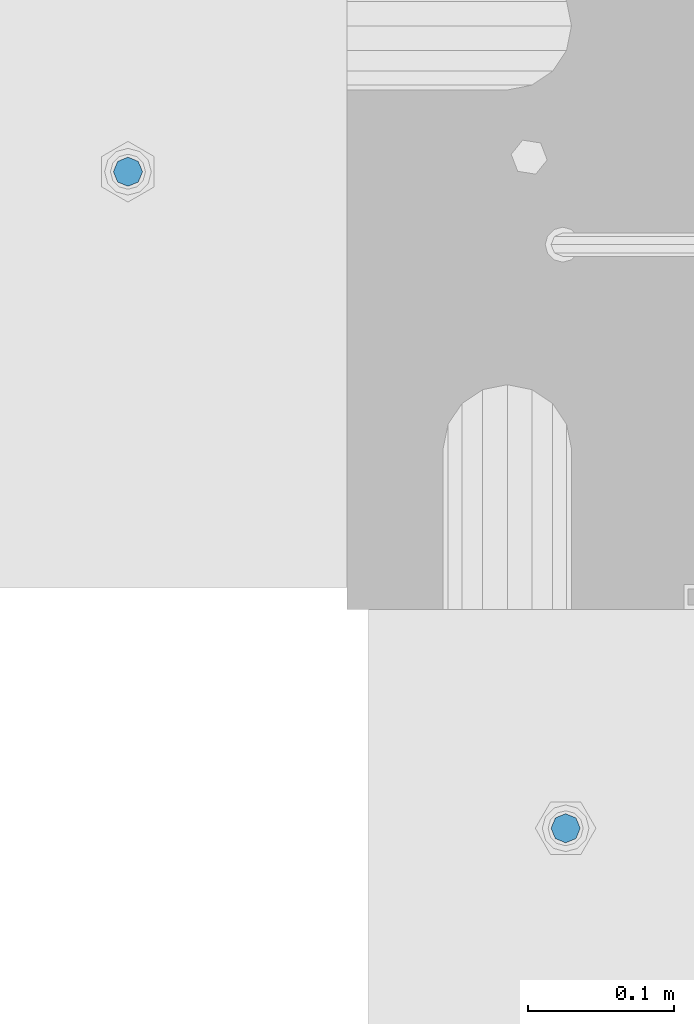
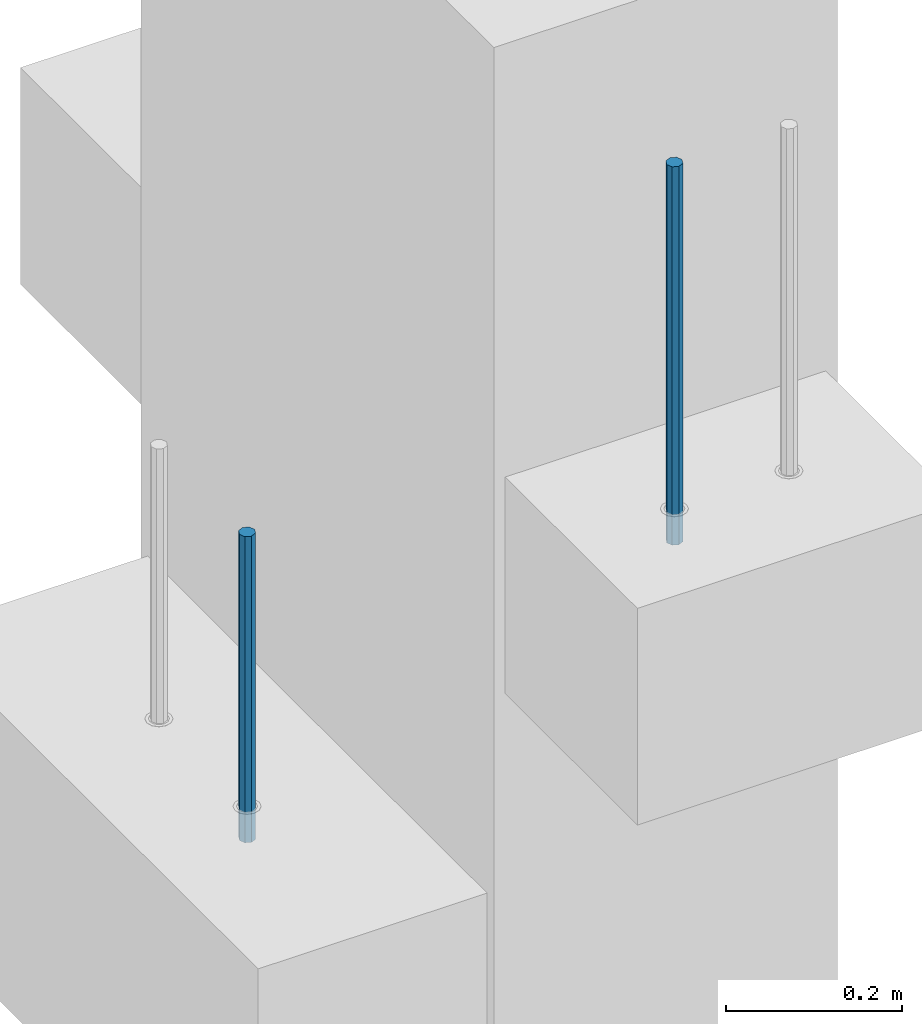
# One storey, part 13 of 41: 2 beams, 1 element without a shape of its own.
"""IFC2X3 building model written with IfcOpenShell, lengths in millimetres."""

from ifc_helpers import new_model, si_unit, frame, origin_with_axes, place, context, subcontext, project, spatial, faceted_brep, material, type_object, element, aggregate, save


model = new_model("IFC2X3")

# Units and contexts
model_context = context("Model", 3, precision=1e-05, world=origin_with_axes())
body_context = subcontext(model_context, "Body", "Model", "MODEL_VIEW")
ifc_project = project(units=[si_unit("LENGTHUNIT", "METRE", prefix="MILLI"), si_unit("AREAUNIT", "SQUARE_METRE"), si_unit("VOLUMEUNIT", "CUBIC_METRE"), si_unit("MASSUNIT", "GRAM", prefix="KILO"), si_unit("TIMEUNIT", "SECOND"), si_unit("PLANEANGLEUNIT", "RADIAN"), si_unit("SOLIDANGLEUNIT", "STERADIAN"), si_unit("THERMODYNAMICTEMPERATUREUNIT", "DEGREE_CELSIUS"), si_unit("LUMINOUSINTENSITYUNIT", "LUMEN")], contexts=[model_context])

# Site, building, storey
site_placement = place(None, frame((-177556.685383467, -198018.589999756, 1290.0), z_axis=(0.0, 0.0, 1.0), x_axis=(0.788225611989142, -0.615386370180835, 0.0)))
site = spatial("IfcSite", under=ifc_project, at=site_placement, CompositionType="ELEMENT")
building_placement = place(site_placement, origin_with_axes())
building = spatial("IfcBuilding", under=site, at=building_placement, Name="Undefined", CompositionType="ELEMENT")
storey_placement = place(building_placement, origin_with_axes())
storey = spatial("IfcBuildingStorey", under=building, at=storey_placement, Name="Undefined", CompositionType="ELEMENT", Elevation=0.0)

# Assembly, beams
assembly_placement = place(storey_placement, origin_with_axes())
assembly = element("IfcElementAssembly", 1, at=assembly_placement, inside=storey, AssemblyPlace="NOTDEFINED", PredefinedType="REINFORCEMENT_UNIT")
ifc_material = material(Name="STEEL/S235JR")
beam_type = type_object("IfcBeamType", PredefinedType="NOTDEFINED")
beam_1_placement = place(assembly_placement, frame((18376.1312535663, 264869.610342897, 17750.0), z_axis=(0.615386370178831, -0.788225611990706, 0.0), x_axis=(0.0, 0.0, -1.0)))
beam_1 = element("IfcBeam", 2, at=beam_1_placement, type_object=beam_type, material=ifc_material, context=body_context, shape_type="Brep", body=[
    faceted_brep([(4.88085788674653e-07, -10.0, -3.86498868465424e-08), (0.0, -7.07106819456385, -7.07106766643119), (524.0, -7.07106759562157, -7.07106811032281), (524.0, -9.99999978375854, -2.98430677503347e-07), (4.97872867461239e-11, -3.88578058618805e-15, -10.0), (524.0, 2.16212356463075e-07, -10.000000298518), (0.0, 7.07106742914766, -7.0710676664894), (524.0, 7.07106802810449, -7.07106811041012), (4.88085788674653e-07, 10.0, -3.86498868465424e-08), (524.0, 10.0000002162415, -2.98547092825174e-07), (0.0, 7.07106742919132, 7.07106795720756), (524.0, 7.0710680281336, 7.07106751331594), (-4.97872867461239e-11, 0.0, 10.0), (524.0, 2.16299667954445e-07, 9.99999970148201), (0.0, -7.07106819453475, 7.07106795729487), (524.0, -7.07106759559247, 7.07106751340325)], [[[0, 1, 2, 3]], [[1, 4, 5, 2]], [[4, 6, 7, 5]], [[6, 8, 9, 7]], [[8, 10, 11, 9]], [[10, 12, 13, 11]], [[12, 14, 15, 13]], [[14, 0, 3, 15]], [[5, 7, 9, 11, 13, 15, 3, 2]], [[14, 12, 10, 8, 6, 4, 1, 0]]]),
])
beam_2_placement = place(assembly_placement, frame((17862.7397033917, 265039.69595724, 17070.0), z_axis=(-0.788225611989142, -0.615386370180835, 0.0), x_axis=(0.0, 0.0, -1.0)))
beam_2 = element("IfcBeam", 3, at=beam_2_placement, type_object=beam_type, material=ifc_material, context=body_context, shape_type="Brep", body=[
    faceted_brep([(4.88085788674653e-07, -10.0, -3.86498868465424e-08), (0.0, -7.07106819456385, -7.07106766643119), (424.0, -7.07106751357787, -7.07106759684393), (424.0, -9.99999970174395, 2.15019099414349e-07), (4.97872867461239e-11, -3.88578058618805e-15, -10.0), (424.0, 2.98285158351064e-07, -9.9999997849518), (0.0, 7.07106742914766, -7.0710676664894), (424.0, 7.07106811014819, -7.07106759675662), (4.88085788674653e-07, 10.0, -3.86498868465424e-08), (424.0, 10.0000002982561, 2.15106410905719e-07), (0.0, 7.07106742919132, 7.07106795720756), (424.0, 7.07106811011909, 7.07106802696944), (-4.97872867461239e-11, 0.0, 10.0), (424.0, 2.98256054520607e-07, 10.0000002150773), (0.0, -7.07106819453475, 7.07106795729487), (424.0, -7.07106751357787, 7.07106802688213)], [[[0, 1, 2, 3]], [[1, 4, 5, 2]], [[4, 6, 7, 5]], [[6, 8, 9, 7]], [[8, 10, 11, 9]], [[10, 12, 13, 11]], [[12, 14, 15, 13]], [[14, 0, 3, 15]], [[5, 7, 9, 11, 13, 15, 3, 2]], [[14, 12, 10, 8, 6, 4, 1, 0]]]),
])
aggregate(assembly, [beam_1, beam_2])

save(model, "model.ifc")
